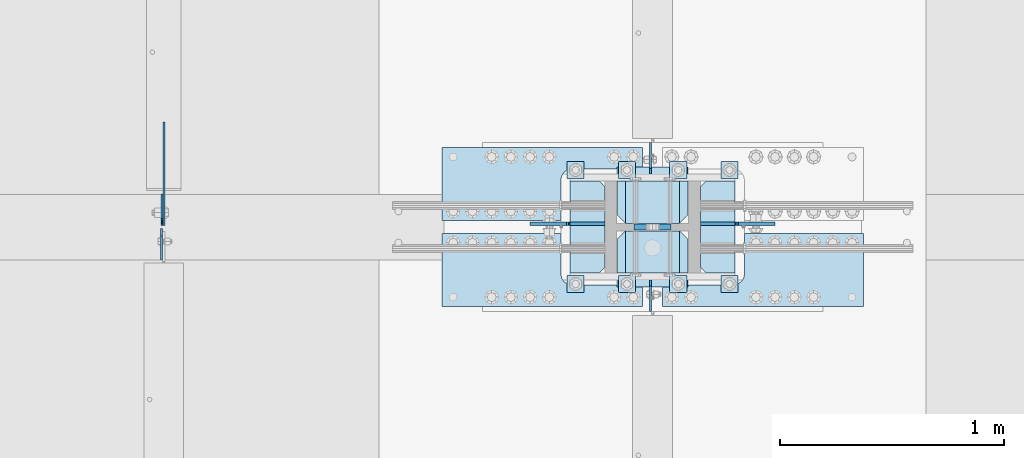
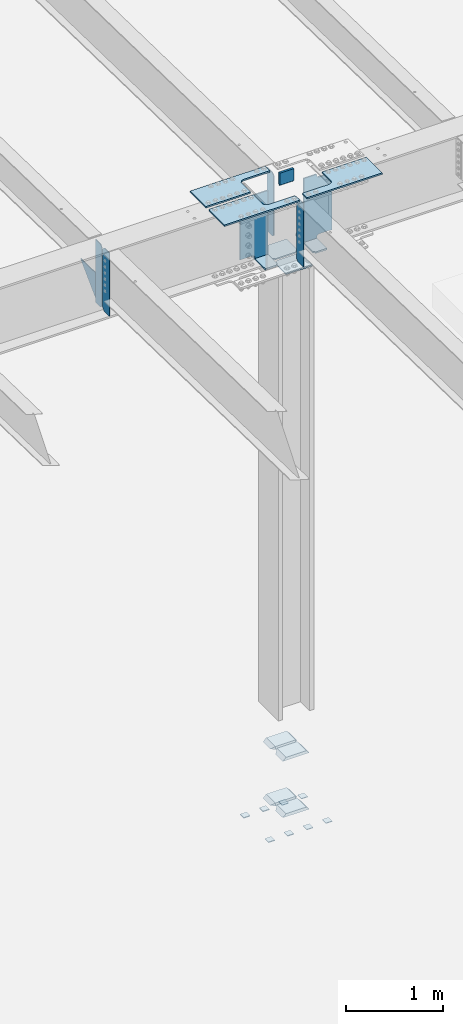
# One storey, part 1488 of 1763: 27 plates, 7 elements without a shape of their own.
"""IFC2X3 building model written with IfcOpenShell, lengths in millimetres."""

from ifc_helpers import new_model, si_unit, frame, origin_with_axes, place, context, subcontext, project, spatial, faceted_brep, material, type_object, element, aggregate, save


model = new_model("IFC2X3")

# Units and contexts
model_context = context("Model", 3, precision=1e-05, world=origin_with_axes())
body_context = subcontext(model_context, "Body", "Model", "MODEL_VIEW")
ifc_project = project(units=[si_unit("LENGTHUNIT", "METRE", prefix="MILLI"), si_unit("AREAUNIT", "SQUARE_METRE"), si_unit("VOLUMEUNIT", "CUBIC_METRE"), si_unit("MASSUNIT", "GRAM", prefix="KILO"), si_unit("TIMEUNIT", "SECOND"), si_unit("PLANEANGLEUNIT", "RADIAN"), si_unit("SOLIDANGLEUNIT", "STERADIAN"), si_unit("THERMODYNAMICTEMPERATUREUNIT", "DEGREE_CELSIUS"), si_unit("LUMINOUSINTENSITYUNIT", "LUMEN")], contexts=[model_context])

# Site, building, storey
site_placement = place(None, origin_with_axes())
site = spatial("IfcSite", under=ifc_project, at=site_placement, CompositionType="ELEMENT")
building_placement = place(site_placement, origin_with_axes())
building = spatial("IfcBuilding", under=site, at=building_placement, Name="Undefined", CompositionType="ELEMENT")
storey_placement = place(building_placement, origin_with_axes())
storey = spatial("IfcBuildingStorey", under=building, at=storey_placement, Name="Undefined", CompositionType="ELEMENT", Elevation=0.0)

# Assembly, plates
assembly_1_placement = place(storey_placement, origin_with_axes())
assembly_1 = element("IfcElementAssembly", 1, at=assembly_1_placement, inside=storey, Name="TEMPLATE", AssemblyPlace="NOTDEFINED", PredefinedType="RIGID_FRAME")
ifc_material_1 = material(Name="STEEL/A36")
plate_type_1 = type_object("IfcPlateType", PredefinedType="NOTDEFINED")
plate_1_placement = place(assembly_1_placement, frame((-61289.6372736986, 241.300000000006, 3916.3625), z_axis=(0.0, -1.0, 0.0), x_axis=(1.0, 0.0, 0.0)))
plate_1 = element("IfcPlate", 2, at=plate_1_placement, type_object=plate_type_1, material=ifc_material_1, Name="WASHER PLATE", context=body_context, shape_type="Brep", body=[
    faceted_brep([(0.0, -4.76249999999982, 0.0), (0.0, -4.76250000000073, 76.1999969482422), (0.0, 4.76250000000073, 76.1999969482422), (0.0, 4.76249999999982, 0.0), (76.1999969482422, -4.76249999999982, 76.1999969482422), (76.1999969482422, 4.76249999999982, 76.1999969482422), (76.1999969482931, -4.76249999991705, 0.0), (76.1999969482931, 4.76250000006257, 1.81898940354586e-12)], [[[0, 1, 2, 3]], [[1, 4, 5, 2]], [[4, 6, 7, 5]], [[6, 0, 3, 7]], [[5, 7, 3, 2]], [[6, 4, 1, 0]]]),
])
plate_2_placement = place(assembly_1_placement, frame((-61289.6372736986, 749.300000000006, 3916.3625), z_axis=(0.0, -1.0, 0.0), x_axis=(1.0, 0.0, 0.0)))
plate_2 = element("IfcPlate", 3, at=plate_2_placement, type_object=plate_type_1, material=ifc_material_1, Name="WASHER PLATE", context=body_context, shape_type="Brep", body=[
    faceted_brep([(0.0, -4.76249999999982, 0.0), (0.0, -4.76250000000073, 76.1999969482422), (0.0, 4.76250000000073, 76.1999969482422), (0.0, 4.76249999999982, 0.0), (76.1999969482422, -4.76249999999982, 76.1999969482422), (76.1999969482422, 4.76249999999982, 76.1999969482422), (76.1999969482931, -4.76249999991705, 0.0), (76.1999969482931, 4.76250000006257, 1.81898940354586e-12)], [[[0, 1, 2, 3]], [[1, 4, 5, 2]], [[4, 6, 7, 5]], [[6, 0, 3, 7]], [[5, 7, 3, 2]], [[6, 4, 1, 0]]]),
])
plate_3_placement = place(assembly_1_placement, frame((-61518.2372736986, 241.300000000006, 3916.3625), z_axis=(0.0, -1.0, 0.0), x_axis=(1.0, 0.0, 0.0)))
plate_3 = element("IfcPlate", 4, at=plate_3_placement, type_object=plate_type_1, material=ifc_material_1, Name="WASHER PLATE", context=body_context, shape_type="Brep", body=[
    faceted_brep([(0.0, -4.76249999999982, 0.0), (0.0, -4.76250000000073, 76.1999969482422), (0.0, 4.76250000000073, 76.1999969482422), (0.0, 4.76249999999982, 0.0), (76.1999969482422, -4.76249999999982, 76.1999969482422), (76.1999969482422, 4.76249999999982, 76.1999969482422), (76.1999969482931, -4.76249999991705, 0.0), (76.1999969482931, 4.76250000006257, 1.81898940354586e-12)], [[[0, 1, 2, 3]], [[1, 4, 5, 2]], [[4, 6, 7, 5]], [[6, 0, 3, 7]], [[5, 7, 3, 2]], [[6, 4, 1, 0]]]),
])
plate_4_placement = place(assembly_1_placement, frame((-61518.2372736986, 749.300000000006, 3916.3625), z_axis=(0.0, -1.0, 0.0), x_axis=(1.0, 0.0, 0.0)))
plate_4 = element("IfcPlate", 5, at=plate_4_placement, type_object=plate_type_1, material=ifc_material_1, Name="WASHER PLATE", context=body_context, shape_type="Brep", body=[
    faceted_brep([(0.0, -4.76249999999982, 0.0), (0.0, -4.76250000000073, 76.1999969482422), (0.0, 4.76250000000073, 76.1999969482422), (0.0, 4.76249999999982, 0.0), (76.1999969482422, -4.76249999999982, 76.1999969482422), (76.1999969482422, 4.76249999999982, 76.1999969482422), (76.1999969482931, -4.76249999991705, 0.0), (76.1999969482931, 4.76250000006257, 1.81898940354586e-12)], [[[0, 1, 2, 3]], [[1, 4, 5, 2]], [[4, 6, 7, 5]], [[6, 0, 3, 7]], [[5, 7, 3, 2]], [[6, 4, 1, 0]]]),
])
plate_5_placement = place(assembly_1_placement, frame((-61746.8372736986, 241.300000000006, 3916.3625), z_axis=(0.0, -1.0, 0.0), x_axis=(1.0, 0.0, 0.0)))
plate_5 = element("IfcPlate", 6, at=plate_5_placement, type_object=plate_type_1, material=ifc_material_1, Name="WASHER PLATE", context=body_context, shape_type="Brep", body=[
    faceted_brep([(0.0, -4.76249999999982, 0.0), (0.0, -4.76250000000073, 76.1999969482422), (0.0, 4.76250000000073, 76.1999969482422), (0.0, 4.76249999999982, 0.0), (76.1999969482422, -4.76249999999982, 76.1999969482422), (76.1999969482422, 4.76249999999982, 76.1999969482422), (76.1999969482931, -4.76249999991705, 0.0), (76.1999969482931, 4.76250000006257, 1.81898940354586e-12)], [[[0, 1, 2, 3]], [[1, 4, 5, 2]], [[4, 6, 7, 5]], [[6, 0, 3, 7]], [[5, 7, 3, 2]], [[6, 4, 1, 0]]]),
])
plate_6_placement = place(assembly_1_placement, frame((-61746.8372736986, 749.300000000006, 3916.3625), z_axis=(0.0, -1.0, 0.0), x_axis=(1.0, 0.0, 0.0)))
plate_6 = element("IfcPlate", 7, at=plate_6_placement, type_object=plate_type_1, material=ifc_material_1, Name="WASHER PLATE", context=body_context, shape_type="Brep", body=[
    faceted_brep([(0.0, -4.76249999999982, 0.0), (0.0, -4.76250000000073, 76.1999969482422), (0.0, 4.76250000000073, 76.1999969482422), (0.0, 4.76249999999982, 0.0), (76.1999969482422, -4.76249999999982, 76.1999969482422), (76.1999969482422, 4.76249999999982, 76.1999969482422), (76.1999969482931, -4.76249999991705, 0.0), (76.1999969482931, 4.76250000006257, 1.81898940354586e-12)], [[[0, 1, 2, 3]], [[1, 4, 5, 2]], [[4, 6, 7, 5]], [[6, 0, 3, 7]], [[5, 7, 3, 2]], [[6, 4, 1, 0]]]),
])
plate_7_placement = place(assembly_1_placement, frame((-61975.4372736986, 241.300000000006, 3916.3625), z_axis=(0.0, -1.0, 0.0), x_axis=(1.0, 0.0, 0.0)))
plate_7 = element("IfcPlate", 8, at=plate_7_placement, type_object=plate_type_1, material=ifc_material_1, Name="WASHER PLATE", context=body_context, shape_type="Brep", body=[
    faceted_brep([(0.0, -4.76249999999982, 0.0), (0.0, -4.76250000000073, 76.1999969482422), (0.0, 4.76250000000073, 76.1999969482422), (0.0, 4.76249999999982, 0.0), (76.1999969482422, -4.76249999999982, 76.1999969482422), (76.1999969482422, 4.76249999999982, 76.1999969482422), (76.1999969482931, -4.76249999991705, 0.0), (76.1999969482931, 4.76250000006257, 1.81898940354586e-12)], [[[0, 1, 2, 3]], [[1, 4, 5, 2]], [[4, 6, 7, 5]], [[6, 0, 3, 7]], [[5, 7, 3, 2]], [[6, 4, 1, 0]]]),
])
plate_8_placement = place(assembly_1_placement, frame((-61975.4372736986, 749.300000000006, 3916.3625), z_axis=(0.0, -1.0, 0.0), x_axis=(1.0, 0.0, 0.0)))
plate_8 = element("IfcPlate", 9, at=plate_8_placement, type_object=plate_type_1, material=ifc_material_1, Name="WASHER PLATE", context=body_context, shape_type="Brep", body=[
    faceted_brep([(0.0, -4.76249999999982, 0.0), (0.0, -4.76250000000073, 76.1999969482422), (0.0, 4.76250000000073, 76.1999969482422), (0.0, 4.76249999999982, 0.0), (76.1999969482422, -4.76249999999982, 76.1999969482422), (76.1999969482422, 4.76249999999982, 76.1999969482422), (76.1999969482931, -4.76249999991705, 0.0), (76.1999969482931, 4.76250000006257, 1.81898940354586e-12)], [[[0, 1, 2, 3]], [[1, 4, 5, 2]], [[4, 6, 7, 5]], [[6, 0, 3, 7]], [[5, 7, 3, 2]], [[6, 4, 1, 0]]]),
])
aggregate(assembly_1, [plate_1, plate_2, plate_3, plate_4, plate_5, plate_6, plate_7, plate_8])

assembly_2_placement = place(storey_placement, origin_with_axes())
assembly_2 = element("IfcElementAssembly", 10, at=assembly_2_placement, inside=storey, Name="COLUMN", AssemblyPlace="NOTDEFINED", PredefinedType="RIGID_FRAME")
plate_type_2 = type_object("IfcPlateType", PredefinedType="NOTDEFINED")
plate_9_placement = place(assembly_2_placement, frame((-61435.6872736986, 252.412500000006, 4826.0), z_axis=(-1.0, 0.0, 0.0), x_axis=(0.0, 1.0, 0.0)))
plate_9 = element("IfcPlate", 11, at=plate_9_placement, type_object=plate_type_2, material=ifc_material_1, Name="PLATE", context=body_context, shape_type="Brep", body=[
    faceted_brep([(188.118743896484, -19.0500000000002, 279.400001525879), (150.018745422363, 19.0500000000002, 317.5), (-1.13686837721616e-13, 19.0500000000002, 317.5), (-1.13686837721616e-13, -19.0500000000002, 279.400000002177), (188.118743896484, -19.0500000000002, 38.0999984741211), (0.0, -19.0500000000002, 38.099999997823), (0.0, 19.0500000000029, 0.0), (150.018745422363, 19.0500000000002, 0.0), (188.118743896484, 19.0500000000002, 38.0999984741211), (188.118743896484, 19.0500000000002, 279.400001525879)], [[[0, 1, 2, 3]], [[4, 5, 6, 7]], [[8, 4, 7]], [[0, 4, 8, 9]], [[5, 4, 0, 3]], [[6, 5, 3, 2]], [[9, 8, 7, 6, 2, 1]], [[9, 1, 0]]]),
])
plate_10_placement = place(assembly_2_placement, frame((-61435.6872736986, 473.868750000006, 4826.0), z_axis=(-1.0, 0.0, 0.0), x_axis=(0.0, 1.0, 0.0)))
plate_10 = element("IfcPlate", 12, at=plate_10_placement, type_object=plate_type_2, material=ifc_material_1, Name="PLATE", context=body_context, shape_type="Brep", body=[
    faceted_brep([(188.118743896484, -19.0500000000002, 38.0999984741211), (0.0, -19.0500000000002, 38.099999997823), (38.0999984741211, 19.0500000000002, 0.0), (188.118743896484, 19.0500000000002, 0.0), (0.0, 19.0500000000002, 38.0999984741211), (0.0, 19.0500000000002, 279.400001525879), (-1.13686837721616e-13, -19.0500000000002, 279.400000002177), (38.0999984741211, 19.0500000000002, 317.5), (188.118743896484, 19.0500000000002, 317.5), (188.118743896484, -19.0500000000002, 279.400001525879)], [[[0, 1, 2, 3]], [[4, 2, 1]], [[5, 6, 7]], [[8, 7, 6, 9]], [[8, 9, 0, 3]], [[4, 5, 7, 8, 3, 2]], [[1, 6, 5, 4]], [[1, 0, 9, 6]]]),
])
plate_11_placement = place(assembly_2_placement, frame((-61435.6872736986, 252.412500000006, 4114.8), z_axis=(-1.0, 0.0, 0.0), x_axis=(0.0, 1.0, 0.0)))
plate_11 = element("IfcPlate", 13, at=plate_11_placement, type_object=plate_type_2, material=ifc_material_1, Name="PLATE", context=body_context, shape_type="Brep", body=[
    faceted_brep([(188.118743896484, -19.0500000000002, 279.400001525879), (150.018745422363, 19.0500000000002, 317.5), (-1.13686837721616e-13, 19.0500000000002, 317.5), (-1.13686837721616e-13, -19.0500000000002, 279.400000002177), (188.118743896484, -19.0500000000002, 38.0999984741211), (0.0, -19.0500000000002, 38.099999997823), (0.0, 19.0500000000029, 0.0), (150.018745422363, 19.0500000000002, 0.0), (188.118743896484, 19.0500000000002, 38.0999984741211), (188.118743896484, 19.0500000000002, 279.400001525879)], [[[0, 1, 2, 3]], [[4, 5, 6, 7]], [[8, 4, 7]], [[0, 4, 8, 9]], [[5, 4, 0, 3]], [[6, 5, 3, 2]], [[9, 8, 7, 6, 2, 1]], [[9, 1, 0]]]),
])
plate_12_placement = place(assembly_2_placement, frame((-61435.6872736986, 473.868750000006, 4114.8), z_axis=(-1.0, 0.0, 0.0), x_axis=(0.0, 1.0, 0.0)))
plate_12 = element("IfcPlate", 14, at=plate_12_placement, type_object=plate_type_2, material=ifc_material_1, Name="PLATE", context=body_context, shape_type="Brep", body=[
    faceted_brep([(188.118743896484, -19.0500000000002, 38.0999984741211), (0.0, -19.0500000000002, 38.099999997823), (38.0999984741211, 19.0500000000002, 0.0), (188.118743896484, 19.0500000000002, 0.0), (0.0, 19.0500000000002, 38.0999984741211), (0.0, 19.0500000000002, 279.400001525879), (-1.13686837721616e-13, -19.0500000000002, 279.400000002177), (38.0999984741211, 19.0500000000002, 317.5), (188.118743896484, 19.0500000000002, 317.5), (188.118743896484, -19.0500000000002, 279.400001525879)], [[[0, 1, 2, 3]], [[4, 2, 1]], [[5, 6, 7]], [[8, 7, 6, 9]], [[8, 9, 0, 3]], [[4, 5, 7, 8, 3, 2]], [[1, 6, 5, 4]], [[1, 0, 9, 6]]]),
])
ifc_material_2 = material(Name="STEEL/A572-50")
plate_type_3 = type_object("IfcPlateType", PredefinedType="NOTDEFINED")
plate_13_placement = place(assembly_2_placement, frame((-61511.8872721725, 457.200000000008, 12073.4961653918), z_axis=(0.0, 0.0, -1.0), x_axis=(-1.0, 0.0, 0.0)))
plate_13 = element("IfcPlate", 15, at=plate_13_placement, type_object=plate_type_3, material=ifc_material_2, Name="PLATE", context=body_context, shape_type="Brep", body=[
    faceted_brep([(0.0, 12.7, 152.399990844726), (-1.45519152283669e-11, 7.27595761418343e-12, 165.099990844727), (165.099990844727, 0.0, 165.099990844727), (165.099990844727, 12.7, 152.399990844726), (0.0, -12.7, 152.399990844726), (165.099990844727, -12.7, 152.399990844726), (0.0, 12.6999999999971, -1.81898940354586e-12), (0.0, -12.6999999999971, -1.81898940354586e-12), (165.099990844727, -12.7, 0.0), (165.099990844727, 12.7, 0.0)], [[[0, 1, 2, 3]], [[1, 4, 5, 2]], [[6, 7, 4, 1, 0]], [[5, 8, 9, 3, 2]], [[8, 7, 6, 9]], [[9, 6, 0, 3]], [[7, 8, 5, 4]]]),
])

# Assembly, plate
assembly_3_placement = place(storey_placement, origin_with_axes())
assembly_3 = element("IfcElementAssembly", 16, at=assembly_3_placement, inside=storey, Name="PLATE", AssemblyPlace="NOTDEFINED", PredefinedType="RIGID_FRAME")
plate_type_4 = type_object("IfcPlateType", PredefinedType="NOTDEFINED")
plate_14_placement = place(assembly_3_placement, frame((-61638.8822232193, 811.21247558596, 11917.9211718243), z_axis=(-1.0, 0.0, 0.0), x_axis=(0.0, -1.0, 0.0)))
plate_14 = element("IfcPlate", 17, at=plate_14_placement, type_object=plate_type_4, material=ifc_material_2, Name="PLATE", context=body_context, shape_type="Brep", body=[
    faceted_brep([(95.2499921933502, -9.52499999999964, 0.0), (95.2499921933502, 9.52499999999964, 0.0), (95.2499921933485, 9.52499999999964, 314.264886800811), (95.2499921933485, -9.52499999999964, 314.264886800811), (99.1169117065035, 9.52499999999964, 333.705204445199), (99.1169117065035, -9.52499999999964, 333.705204445199), (110.12896683078, 9.52499999999964, 350.185910090775), (110.12896683078, -9.52499999999964, 350.185910090775), (126.609672074858, 9.52499999999964, 361.197965815933), (126.609672074858, -9.52499999999964, 361.197965815933), (146.049989578264, 9.52499999999964, 365.064886037871), (146.049989578264, -9.52499999999964, 365.064886037871), (325.437537969715, -9.52499999999964, 365.064892578259), (325.437530517578, 9.52499999999964, 365.064892578259), (0.0, -9.52500000000146, 0.0), (-4.77484718430787e-12, -9.52499999999964, 895.379943847656), (-4.77484718430787e-12, 9.52499999999964, 895.379943847656), (0.0, 9.52500000000146, 0.0), (325.437530517578, -9.52499999999964, 895.379943847656), (325.437530517578, 9.52499999999964, 895.379943847656)], [[[0, 1, 2, 3]], [[3, 2, 4, 5]], [[5, 4, 6, 7]], [[7, 6, 8, 9]], [[9, 8, 10, 11]], [[12, 11, 10, 13]], [[14, 15, 16, 17]], [[15, 18, 19, 16]], [[19, 18, 12, 13]], [[8, 6, 4, 2, 1, 17, 16, 19, 13, 10]], [[14, 17, 1, 0]], [[18, 15, 14, 0, 3, 5, 7, 9, 11, 12]]]),
])
aggregate(assembly_3, [plate_14])

assembly_4_placement = place(storey_placement, origin_with_axes())
assembly_4 = element("IfcElementAssembly", 18, at=assembly_4_placement, inside=storey, Name="PLATE", AssemblyPlace="NOTDEFINED", PredefinedType="RIGID_FRAME")
plate_15_placement = place(assembly_4_placement, frame((-61549.9922661248, 103.187524414039, 11917.9211718243), z_axis=(1.0, 0.0, 0.0), x_axis=(0.0, 1.0, 0.0)))
plate_15 = element("IfcPlate", 19, at=plate_15_placement, type_object=plate_type_4, material=ifc_material_2, Name="PLATE", context=body_context, shape_type="Brep", body=[
    faceted_brep([(95.2499921933502, -9.52499999999964, 0.0), (95.2499921933502, 9.52499999999964, 0.0), (95.2499921933766, 9.52499999999964, 314.329999292531), (95.2499921933766, -9.52499999999964, 314.329999292531), (99.1169118837276, 9.52499999999964, 333.770317364717), (99.1169118837276, -9.52499999999964, 333.770317364717), (110.128967485639, 9.52499999999964, 350.251023237332), (110.128967485639, -9.52499999999964, 350.251023237332), (126.609673358253, 9.52499999999964, 361.263078839242), (126.609673358253, -9.52499999999964, 361.263078839242), (146.049991430434, 9.52499999999964, 365.129998529592), (146.049991430434, -9.52499999999964, 365.129998529592), (325.437522710954, -9.52499999999964, 365.129998529606), (325.437530517578, 9.52499999999964, 365.129998529606), (0.0, -9.52500000000146, 0.0), (-4.77484718430787e-12, -9.52499999999964, 895.380126953125), (-4.77484718430787e-12, 9.52499999999964, 895.380126953125), (0.0, 9.52500000000146, 0.0), (325.437530517578, -9.52499999999964, 895.380126953125), (325.437530517578, 9.52499999999964, 895.380126953125)], [[[0, 1, 2, 3]], [[3, 2, 4, 5]], [[5, 4, 6, 7]], [[7, 6, 8, 9]], [[9, 8, 10, 11]], [[12, 11, 10, 13]], [[14, 15, 16, 17]], [[15, 18, 19, 16]], [[19, 18, 12, 13]], [[8, 6, 4, 2, 1, 17, 16, 19, 13, 10]], [[14, 17, 1, 0]], [[18, 15, 14, 0, 3, 5, 7, 9, 11, 12]]]),
])
aggregate(assembly_4, [plate_15])

assembly_5_placement = place(storey_placement, origin_with_axes())
assembly_5 = element("IfcElementAssembly", 20, at=assembly_5_placement, inside=storey, Name="PLATE", AssemblyPlace="NOTDEFINED", PredefinedType="RIGID_FRAME")
plate_16_placement = place(assembly_5_placement, frame((-61638.8822232193, 103.18752441404, 11917.9211718243), z_axis=(-1.0, 0.0, 0.0), x_axis=(0.0, 1.0, 0.0)))
plate_16 = element("IfcPlate", 21, at=plate_16_placement, type_object=plate_type_4, material=ifc_material_2, Name="PLATE", context=body_context, shape_type="Brep", body=[
    faceted_brep([(95.2499921933502, -9.52499999999964, 0.0), (95.2499921933502, 9.52499999999964, 0.0), (95.2499921933485, 9.52499999999964, 314.264886800811), (95.2499921933485, -9.52499999999964, 314.264886800811), (99.1169117065035, 9.52499999999964, 333.705204445199), (99.1169117065035, -9.52499999999964, 333.705204445199), (110.12896683078, 9.52499999999964, 350.185910090775), (110.12896683078, -9.52499999999964, 350.185910090775), (126.609672074858, 9.52499999999964, 361.197965815933), (126.609672074858, -9.52499999999964, 361.197965815933), (146.049989578264, 9.52499999999964, 365.064886037871), (146.049989578264, -9.52499999999964, 365.064886037871), (325.437537969715, -9.52499999999964, 365.064892578259), (325.437530517578, 9.52499999999964, 365.064892578259), (0.0, -9.52500000000146, 0.0), (-4.77484718430787e-12, -9.52499999999964, 895.379943847656), (-4.77484718430787e-12, 9.52499999999964, 895.379943847656), (0.0, 9.52500000000146, 0.0), (325.437530517578, -9.52499999999964, 895.379943847656), (325.437530517578, 9.52499999999964, 895.379943847656)], [[[0, 1, 2, 3]], [[3, 2, 4, 5]], [[5, 4, 6, 7]], [[7, 6, 8, 9]], [[9, 8, 10, 11]], [[12, 11, 10, 13]], [[14, 15, 16, 17]], [[15, 18, 19, 16]], [[19, 18, 12, 13]], [[8, 6, 4, 2, 1, 17, 16, 19, 13, 10]], [[14, 17, 1, 0]], [[18, 15, 14, 0, 3, 5, 7, 9, 11, 12]]]),
])
aggregate(assembly_5, [plate_16])

# Plate
plate_type_5 = type_object("IfcPlateType", PredefinedType="NOTDEFINED")
plate_17_placement = place(assembly_2_placement, frame((-61807.1622750915, 661.987506472742, 11076.5461713619), z_axis=(0.0, -1.0, 0.0), x_axis=(-1.0, 0.0, 0.0)))
plate_17 = element("IfcPlate", 22, at=plate_17_placement, type_object=plate_type_5, material=ifc_material_2, Name="PLATE", context=body_context, shape_type="Brep", body=[
    faceted_brep([(2.91038304567337e-11, -9.52499999999418, 25.4000000000015), (1.38243194669485e-10, -9.52500000000146, 384.175012588501), (1.67347025126219e-10, 9.52499999999782, 384.175012588501), (-5.82076609134674e-11, 9.52499999999418, 25.4000000000015), (25.3999996186831, -9.52499999999054, 409.575012207031), (25.3999996187049, 9.52500000001055, 409.575012207031), (155.574981689446, -9.52499999993961, 409.575012207031), (155.574981689468, 9.5250000000633, 409.575012207031), (155.574981689446, -9.52499999993961, -5.6843418860808e-13), (155.574981689468, 9.5250000000633, -5.6843418860808e-13), (25.399999618523, -9.52499999999054, -1.13686837721616e-13), (25.3999996185448, 9.52500000001055, -1.13686837721616e-13)], [[[0, 1, 2, 3]], [[1, 4, 5, 2]], [[4, 6, 7, 5]], [[6, 8, 9, 7]], [[8, 10, 11, 9]], [[10, 0, 3, 11]], [[5, 7, 9, 11, 3, 2]], [[10, 8, 6, 4, 1, 0]]]),
])

plate_18_placement = place(assembly_2_placement, frame((-61381.712303679, 252.412500000019, 11076.5461711508), z_axis=(0.0, 1.0, 0.0), x_axis=(1.0, 0.0, 0.0)))
plate_18 = element("IfcPlate", 23, at=plate_18_placement, type_object=plate_type_5, material=ifc_material_2, Name="PLATE", context=body_context, shape_type="Brep", body=[
    faceted_brep([(2.91038304567337e-11, -9.52499999999418, 25.4000000000015), (1.38243194669485e-10, -9.52500000000146, 384.175012588501), (1.67347025126219e-10, 9.52499999999782, 384.175012588501), (-5.82076609134674e-11, 9.52499999999418, 25.4000000000015), (25.3999996186831, -9.52499999999054, 409.575012207031), (25.3999996187049, 9.52500000001055, 409.575012207031), (155.574981689446, -9.52499999993961, 409.575012207031), (155.574981689468, 9.5250000000633, 409.575012207031), (155.574981689446, -9.52499999993961, -5.6843418860808e-13), (155.574981689468, 9.5250000000633, -5.6843418860808e-13), (25.399999618523, -9.52499999999054, -1.13686837721616e-13), (25.3999996185448, 9.52500000001055, -1.13686837721616e-13)], [[[0, 1, 2, 3]], [[1, 4, 5, 2]], [[4, 6, 7, 5]], [[6, 8, 9, 7]], [[8, 10, 11, 9]], [[10, 0, 3, 11]], [[5, 7, 9, 11, 3, 2]], [[10, 8, 6, 4, 1, 0]]]),
])

# Assembly, plate
assembly_6_placement = place(storey_placement, origin_with_axes())
assembly_6 = element("IfcElementAssembly", 24, at=assembly_6_placement, inside=storey, Name="BEAM", AssemblyPlace="NOTDEFINED", PredefinedType="RIGID_FRAME")
plate_type_6 = type_object("IfcPlateType", PredefinedType="NOTDEFINED")
plate_19_placement = place(assembly_6_placement, frame((-63783.2827736144, 450.056250000003, 11090.8336714953), z_axis=(0.0, 0.0, 1.0), x_axis=(0.0, -1.0, 0.0)))
plate_19 = element("IfcPlate", 25, at=plate_19_placement, type_object=plate_type_6, material=ifc_material_1, Name="PLATE", context=body_context, shape_type="Brep", body=[
    faceted_brep([(0.0, -4.76250000000073, 31.75), (0.0, -4.76249999999709, 763.587524414062), (0.0, 4.76249999999709, 763.587524414062), (0.0, 4.76250000000073, 31.75), (31.75, -4.76249999999709, 795.337524414062), (31.75, 4.76249999999709, 795.337524414062), (139.699996948242, -4.76249999999709, 795.337524414062), (139.699996948242, 4.76249999999709, 795.337524414062), (139.699996948242, -4.76249999999709, 0.0), (139.699996948242, 4.76249999999709, 0.0), (31.75, -4.76250000000073, 0.0), (31.75, 4.76250000000073, 0.0)], [[[0, 1, 2, 3]], [[1, 4, 5, 2]], [[4, 6, 7, 5]], [[6, 8, 9, 7]], [[8, 10, 11, 9]], [[10, 0, 3, 11]], [[5, 7, 9, 11, 3, 2]], [[10, 8, 6, 4, 1, 0]]]),
])

# Plate
plate_20_placement = place(assembly_2_placement, frame((-61603.9617737837, 693.737499988587, 11887.8139109634), z_axis=(0.0, 1.0, 0.0), x_axis=(0.0, 0.0, -1.0)))
plate_20 = element("IfcPlate", 26, at=plate_20_placement, type_object=plate_type_6, material=ifc_material_1, Name="PLATE", context=body_context, shape_type="Brep", body=[
    faceted_brep([(0.0, -4.76250000000073, 25.3999996185303), (-1.4915713109076e-10, -4.76249999999709, 139.699996948242), (-1.4915713109076e-10, 4.76249999999709, 139.699996948242), (0.0, 4.76250000000073, 25.3999996185303), (800.099975585863, -4.76249999999709, 139.69999694821), (800.099975585863, 4.76249999999709, 139.69999694821), (800.099975585923, -4.76249999999709, 25.3999996180664), (800.099975585923, 4.76249999999709, 25.3999996180664), (774.699975967405, -4.76249999999709, -4.49063009000383e-10), (774.699975967405, 4.76249999999709, -4.49063009000383e-10), (25.3999996185303, -4.76250000000073, 0.0), (25.3999996185303, 4.76250000000073, 0.0)], [[[0, 1, 2, 3]], [[1, 4, 5, 2]], [[4, 6, 7, 5]], [[6, 8, 9, 7]], [[8, 10, 11, 9]], [[10, 0, 3, 11]], [[5, 7, 9, 11, 3, 2]], [[10, 8, 6, 4, 1, 0]]]),
])

plate_21_placement = place(assembly_2_placement, frame((-61603.9617737816, 220.662499987563, 11887.6590356366), z_axis=(0.0, -1.0, 0.0), x_axis=(0.0, 0.0, -1.0)))
plate_21 = element("IfcPlate", 27, at=plate_21_placement, type_object=plate_type_6, material=ifc_material_1, Name="PLATE", context=body_context, shape_type="Brep", body=[
    faceted_brep([(0.0, -4.76250000000073, 25.3999996185303), (-1.4915713109076e-10, -4.76249999999709, 139.699996948242), (-1.4915713109076e-10, 4.76249999999709, 139.699996948242), (0.0, 4.76250000000073, 25.3999996185303), (800.099975585863, -4.76249999999709, 139.69999694821), (800.099975585863, 4.76249999999709, 139.69999694821), (800.099975585923, -4.76249999999709, 25.3999996180664), (800.099975585923, 4.76249999999709, 25.3999996180664), (774.699975967405, -4.76249999999709, -4.49063009000383e-10), (774.699975967405, 4.76249999999709, -4.49063009000383e-10), (25.3999996185303, -4.76250000000073, 0.0), (25.3999996185303, 4.76250000000073, 0.0)], [[[0, 1, 2, 3]], [[1, 4, 5, 2]], [[4, 6, 7, 5]], [[6, 8, 9, 7]], [[8, 10, 11, 9]], [[10, 0, 3, 11]], [[5, 7, 9, 11, 3, 2]], [[10, 8, 6, 4, 1, 0]]]),
])

plate_type_7 = type_object("IfcPlateType", PredefinedType="NOTDEFINED")
plate_22_placement = place(assembly_6_placement, frame((-63781.6957737632, 464.343750000003, 11090.8336714953), z_axis=(0.0, 0.0, 1.0), x_axis=(0.0, 1.0, 0.0)))
plate_22 = element("IfcPlate", 28, at=plate_22_placement, type_object=plate_type_7, material=ifc_material_1, Name="PLATE", context=body_context, shape_type="Brep", body=[
    faceted_brep([(0.0, -3.96899999999732, 31.75), (0.0, -3.96899999999732, 763.587524414062), (0.0, 3.96899999999732, 763.587524414062), (0.0, 3.96899999999732, 31.75), (31.75, -3.96899999999732, 795.337524414062), (31.75, 3.96899999999732, 795.337524414062), (139.699996948242, -3.96899999999732, 795.337524414062), (139.699996948242, 3.96899999999732, 795.337524414062), (139.699996948242, -3.96899999999732, 0.0), (139.699996948242, 3.96899999999732, 0.0), (31.75, -3.96899999999732, 0.0), (31.75, 3.96899999999732, 0.0)], [[[0, 1, 2, 3]], [[1, 4, 5, 2]], [[4, 6, 7, 5]], [[6, 8, 9, 7]], [[8, 10, 11, 9]], [[10, 0, 3, 11]], [[5, 7, 9, 11, 3, 2]], [[10, 8, 6, 4, 1, 0]]]),
])

aggregate(assembly_6, [plate_19, plate_22])

plate_type_8 = type_object("IfcPlateType", PredefinedType="NOTDEFINED")
plate_23_placement = place(assembly_2_placement, frame((-61435.6872736986, 188.912500000006, 10982.8837091866), z_axis=(-1.0, 0.0, 0.0), x_axis=(0.0, 1.0, 0.0)))
plate_23 = element("IfcPlate", 29, at=plate_23_placement, type_object=plate_type_8, material=ifc_material_2, Name="PLATE", context=body_context, shape_type="Brep", body=[
    faceted_brep([(-7.27595761418343e-12, -7.9375, 0.0), (0.0, -7.9375, 317.5), (0.0, 7.9375, 317.5), (-7.27595761418343e-12, 7.9375, 0.0), (213.518745422363, -7.9375, 317.5), (213.518745422363, 7.9375, 317.5), (251.618743896484, -7.9375, 279.400001525879), (251.618743896484, 7.9375, 279.400001525879), (251.618743896484, -7.9375, 38.0999984741211), (251.618743896484, 7.9375, 38.0999984741211), (213.518745422363, -7.9375, 0.0), (213.518745422363, 7.9375, 0.0)], [[[0, 1, 2, 3]], [[1, 4, 5, 2]], [[4, 6, 7, 5]], [[6, 8, 9, 7]], [[8, 10, 11, 9]], [[10, 0, 3, 11]], [[5, 7, 9, 11, 3, 2]], [[10, 8, 6, 4, 1, 0]]]),
])

plate_24_placement = place(assembly_2_placement, frame((-61435.6872736986, 473.868750000006, 10982.8837091866), z_axis=(-1.0, 0.0, 0.0), x_axis=(0.0, 1.0, 0.0)))
plate_24 = element("IfcPlate", 30, at=plate_24_placement, type_object=plate_type_8, material=ifc_material_2, Name="PLATE", context=body_context, shape_type="Brep", body=[
    faceted_brep([(0.0, -7.9375, 38.0999984741211), (0.0, -7.9375, 279.400001525879), (0.0, 7.9375, 279.400001525879), (0.0, 7.9375, 38.0999984741211), (38.0999984741211, -7.9375, 317.5), (38.0999984741211, 7.9375, 317.5), (251.618743896484, -7.9375, 317.5), (251.618743896484, 7.9375, 317.5), (251.618743896484, -7.9375, 0.0), (251.618743896484, 7.9375, 0.0), (38.0999984741211, -7.9375, 0.0), (38.0999984741211, 7.9375, 0.0)], [[[0, 1, 2, 3]], [[1, 4, 5, 2]], [[4, 6, 7, 5]], [[6, 8, 9, 7]], [[8, 10, 11, 9]], [[10, 0, 3, 11]], [[5, 7, 9, 11, 3, 2]], [[10, 8, 6, 4, 1, 0]]]),
])

plate_type_9 = type_object("IfcPlateType", PredefinedType="NOTDEFINED")
plate_25_placement = place(assembly_2_placement, frame((-61381.7122736986, 472.281250000003, 11889.3461714953), z_axis=(1.0, 0.0, 0.0), x_axis=(0.0, 0.0, -1.0)))
plate_25 = element("IfcPlate", 31, at=plate_25_placement, type_object=plate_type_9, material=ifc_material_2, Name="PLATE", context=body_context, shape_type="Brep", body=[
    faceted_brep([(17.4625027313377, -7.9375, 155.574972729497), (17.4625027313377, 7.9375, 155.574972729497), (0.0, 7.9375, 155.574972729497), (0.0, -7.9375, 155.574972729497), (27.1826617674287, -7.9375, 157.508432574672), (27.1826617674287, 7.9375, 157.508432574672), (35.423014703736, -7.9375, 163.014460375627), (35.423014703736, 7.9375, 163.014460375627), (40.9290425046929, -7.9375, 171.254813311934), (40.9290425046929, 7.9375, 171.254813311934), (42.862502349868, -7.9375, 180.974972348027), (42.862502349868, 7.9375, 180.974972348027), (42.862502349868, -7.9375, 333.374991040022), (42.862502349868, 7.9375, 333.375), (803.275024414062, -7.9375, 0.0), (-7.27595761418343e-12, -7.9375, 0.0), (-7.27595761418343e-12, 7.9375, 0.0), (803.275024414062, 7.9375, 0.0), (803.275024414062, 7.9375, 155.574937444078), (803.275024414062, -7.9375, 155.574937444078), (785.812508628436, 7.9375, 155.574937444078), (785.812508628436, -7.9375, 155.574937444078), (776.092348837135, 7.9375, 157.508397602076), (776.092348837135, -7.9375, 157.508397602076), (767.85199550001, 7.9375, 163.014426246235), (767.85199550001, -7.9375, 163.014426246235), (762.345967916626, 7.9375, 171.254780292154), (762.345967916626, -7.9375, 171.254780292154), (760.412509009908, 7.9375, 180.974940332351), (760.412509009908, -7.9375, 180.974940332351), (760.412528628351, -7.9375, 333.375), (760.412528628351, 7.9375, 333.375)], [[[0, 1, 2, 3]], [[4, 5, 1, 0]], [[6, 7, 5, 4]], [[8, 9, 7, 6]], [[10, 11, 9, 8]], [[12, 13, 11, 10]], [[14, 15, 16, 17]], [[14, 17, 18, 19]], [[19, 18, 20, 21]], [[21, 20, 22, 23]], [[23, 22, 24, 25]], [[25, 24, 26, 27]], [[27, 26, 28, 29]], [[30, 29, 28, 31]], [[8, 6, 4, 0, 3, 15, 14, 19, 21, 23, 25, 27, 29, 30, 12, 10]], [[16, 15, 3, 2]], [[31, 28, 26, 24, 22, 20, 18, 17, 16, 2, 1, 5, 7, 9, 11, 13]], [[30, 31, 13, 12]]]),
])

plate_26_placement = place(assembly_2_placement, frame((-61807.1622736986, 472.281250000003, 11889.3461714953), z_axis=(-1.0, 0.0, 0.0), x_axis=(0.0, 0.0, -1.0)))
plate_26 = element("IfcPlate", 32, at=plate_26_placement, type_object=plate_type_9, material=ifc_material_2, Name="PLATE", context=body_context, shape_type="Brep", body=[
    faceted_brep([(17.4625027313377, -7.9375, 155.574972729497), (17.4625027313377, 7.9375, 155.574972729497), (0.0, 7.9375, 155.574972729497), (0.0, -7.9375, 155.574972729497), (27.1826617674287, -7.9375, 157.508432574672), (27.1826617674287, 7.9375, 157.508432574672), (35.423014703736, -7.9375, 163.014460375627), (35.423014703736, 7.9375, 163.014460375627), (40.9290425046929, -7.9375, 171.254813311934), (40.9290425046929, 7.9375, 171.254813311934), (42.862502349868, -7.9375, 180.974972348027), (42.862502349868, 7.9375, 180.974972348027), (42.862502349868, -7.9375, 333.374991040022), (42.862502349868, 7.9375, 333.375), (803.275024414062, -7.9375, 0.0), (-7.27595761418343e-12, -7.9375, 0.0), (-7.27595761418343e-12, 7.9375, 0.0), (803.275024414062, 7.9375, 0.0), (803.275024414062, 7.9375, 155.574989183879), (803.275024414062, -7.9375, 155.574989183879), (785.812506702398, 7.9375, 155.574989183879), (785.812506702398, -7.9375, 155.574989183879), (776.092346911095, 7.9375, 157.508449341876), (776.092346911095, -7.9375, 157.508449341876), (767.851993573971, 7.9375, 163.014477986035), (767.851993573971, -7.9375, 163.014477986035), (762.345965990588, 7.9375, 171.254832031955), (762.345965990588, -7.9375, 171.254832031955), (760.412507083869, 7.9375, 180.974992072152), (760.412507083869, -7.9375, 180.974992072152), (760.412528628351, -7.9375, 333.375), (760.412528628351, 7.9375, 333.375)], [[[0, 1, 2, 3]], [[4, 5, 1, 0]], [[6, 7, 5, 4]], [[8, 9, 7, 6]], [[10, 11, 9, 8]], [[12, 13, 11, 10]], [[14, 15, 16, 17]], [[14, 17, 18, 19]], [[19, 18, 20, 21]], [[21, 20, 22, 23]], [[23, 22, 24, 25]], [[25, 24, 26, 27]], [[27, 26, 28, 29]], [[30, 29, 28, 31]], [[8, 6, 4, 0, 3, 15, 14, 19, 21, 23, 25, 27, 29, 30, 12, 10]], [[16, 15, 3, 2]], [[31, 28, 26, 24, 22, 20, 18, 17, 16, 2, 1, 5, 7, 9, 11, 13]], [[30, 31, 13, 12]]]),
])

aggregate(assembly_2, [plate_9, plate_10, plate_11, plate_12, plate_13, plate_23, plate_24, plate_20, plate_21, plate_17, plate_18, plate_25, plate_26])

# Assembly, plate
assembly_7_placement = place(storey_placement, origin_with_axes())
assembly_7 = element("IfcElementAssembly", 33, at=assembly_7_placement, inside=storey, Name="BEAM", AssemblyPlace="NOTDEFINED", PredefinedType="RIGID_FRAME")
plate_type_10 = type_object("IfcPlateType", PredefinedType="NOTDEFINED")
plate_27_placement = place(assembly_7_placement, frame((-63772.9635236983, 464.195254057829, 11124.3909286493), z_axis=(0.0, 0.0, 1.0), x_axis=(0.0, 1.0, 0.0)))
plate_27 = element("IfcPlate", 34, at=plate_27_placement, type_object=plate_type_10, material=ifc_material_1, Name="PLATE", context=body_context, shape_type="Brep", body=[
    faceted_brep([(0.0, -4.76249999999982, 0.0), (0.148495942354202, -4.76249999999709, 329.731689453125), (0.148495942354202, 4.76249999999709, 329.731689453125), (0.0, 4.76249999999982, 0.0), (460.458892822266, -4.76249999999709, 320.108489990234), (460.458892822266, 4.76249999999709, 320.108489990234), (139.699996948242, -4.76249999999709, 0.0), (139.699996948242, 4.76249999999709, 0.0)], [[[0, 1, 2, 3]], [[1, 4, 5, 2]], [[4, 6, 7, 5]], [[6, 0, 3, 7]], [[5, 7, 3, 2]], [[6, 4, 1, 0]]]),
])
aggregate(assembly_7, [plate_27])

save(model, "model.ifc")
